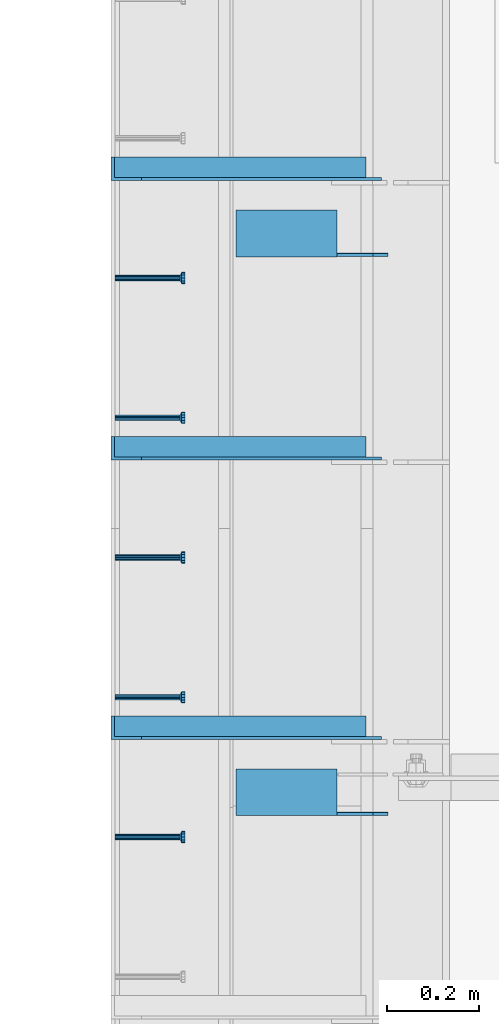
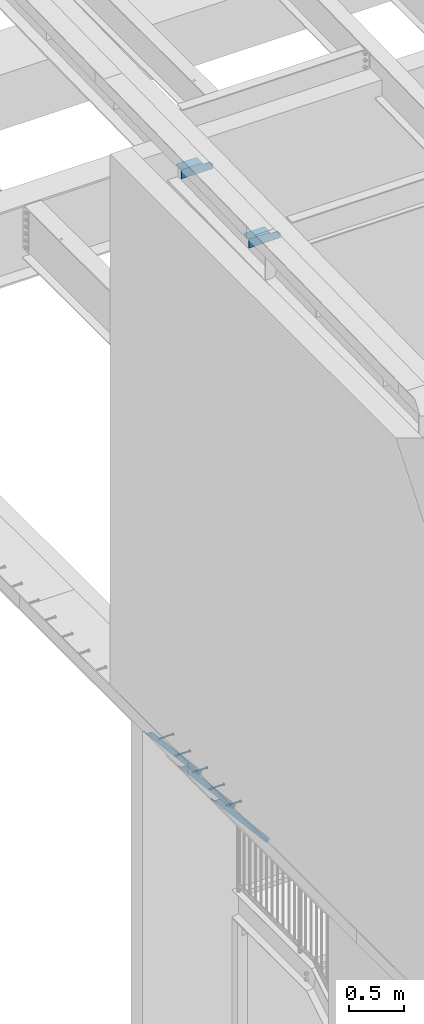
# One storey, part 1270 of 1763: 7 beams, 3 members, 7 elements without a shape of their own.
"""IFC2X3 building model written with IfcOpenShell, lengths in millimetres."""

import ifcopenshell
import ifcopenshell.guid

model = None  # the IFC model being written
_history = None  # IfcOwnerHistory: only IFC2X3 demands one
_inside = {}  # id of a spatial element -> (the spatial element, [elements in it])
_under = {}  # id of a project, library or spatial element -> (it, [spatial elements below it])
_declared = {}  # id of a project -> (the project, [libraries it declares])
_typed = {}  # id of a type object -> (the type object, [elements of that type])
_made_of = {}  # id of a material, layer set ... -> (it, [elements and type objects made of it])


def new_model(schema):
    """Start an empty IFC model of exactly this schema.

    Asked for "IFC4X3", IfcOpenShell would pick the latest addendum, in which some entities
    have other attributes; the version numbers below select the first issue.
    IFC2X3 requires an IfcOwnerHistory on every rooted entity: one is made here for all.
    """
    global model, _history
    if schema == "IFC4X3":
        model = ifcopenshell.file(schema_version=(4, 3, 0, 0))
    else:
        model = ifcopenshell.file(schema=schema)
    _inside.clear()
    _under.clear()
    _declared.clear()
    _typed.clear()
    _made_of.clear()
    _history = None
    if model.schema == "IFC2X3":
        org = make("IfcOrganization", Name="unknown")
        user = make(
            "IfcPersonAndOrganization",
            ThePerson=make("IfcPerson", FamilyName="unknown"),
            TheOrganization=org,
        )
        app = make(
            "IfcApplication",
            ApplicationDeveloper=org,
            Version="unknown",
            ApplicationFullName="unknown",
            ApplicationIdentifier="unknown",
        )
        _history = make(
            "IfcOwnerHistory",
            OwningUser=user,
            OwningApplication=app,
            ChangeAction="ADDED",
            CreationDate=0,
        )
    return model


def make(cls, **values):
    """One entity of the class cls with the attributes given. An attribute that is None is left unset."""
    return model.create_entity(
        cls, **{name: value for name, value in values.items() if value is not None}
    )


def rooted(cls, **values):
    """An entity with a GlobalId (a new one), such as an element, a storey or a relation."""
    return make(cls, GlobalId=ifcopenshell.guid.new(), OwnerHistory=_history, **values)


def si_unit(unit_type, name, prefix=None):
    """IfcSIUnit, for example si_unit("LENGTHUNIT", "METRE", prefix="MILLI")."""
    return make("IfcSIUnit", UnitType=unit_type, Prefix=prefix, Name=name)


def assignment(units):
    """IfcUnitAssignment: the units of a project."""
    return None if units is None else make("IfcUnitAssignment", Units=units)


def point(xyz):
    """IfcCartesianPoint."""
    return None if xyz is None else make("IfcCartesianPoint", Coordinates=xyz)


def direction(xyz):
    """IfcDirection."""
    return None if xyz is None else make("IfcDirection", DirectionRatios=xyz)


def frame(location, z_axis=None, x_axis=None):
    """IfcAxis2Placement3D, a coordinate frame: its origin and axes. An axis left out is left unset."""
    return make(
        "IfcAxis2Placement3D",
        Location=point(location),
        Axis=direction(z_axis),
        RefDirection=direction(x_axis),
    )


def origin_with_axes():
    """The frame at (0, 0, 0) with the z axis (0, 0, 1) and the x axis (1, 0, 0) written out."""
    return frame((0.0, 0.0, 0.0), z_axis=(0.0, 0.0, 1.0), x_axis=(1.0, 0.0, 0.0))


def place(relative_to, where):
    """IfcLocalPlacement: puts the frame where relative to a parent placement (None: the world)."""
    return make(
        "IfcLocalPlacement", PlacementRelTo=relative_to, RelativePlacement=where
    )


def context(
    kind, dimensions, precision=None, world=None, true_north=None, identifier=None
):
    """IfcGeometricRepresentationContext, for example the 3D "Model" context."""
    return make(
        "IfcGeometricRepresentationContext",
        ContextIdentifier=identifier,
        ContextType=kind,
        CoordinateSpaceDimension=dimensions,
        Precision=precision,
        WorldCoordinateSystem=world,
        TrueNorth=true_north,
    )


def subcontext(parent, identifier, kind, view, scale=None):
    """IfcGeometricRepresentationSubContext, for example "Body" below "Model"."""
    return make(
        "IfcGeometricRepresentationSubContext",
        ContextIdentifier=identifier,
        ContextType=kind,
        ParentContext=parent,
        TargetScale=scale,
        TargetView=view,
    )


def project(units=None, contexts=None):
    """IfcProject with its units and contexts."""
    return rooted(
        "IfcProject",
        Name="project",
        RepresentationContexts=contexts,
        UnitsInContext=assignment(units),
    )


def spatial(cls, under=None, at=None, **own):
    """A site, building, storey or space (cls), placed at a placement, below another one or the project."""
    s = rooted(cls, ObjectPlacement=at, **own)
    if under is not None:
        _under.setdefault(under.id(), (under, []))[1].append(s)
    return s


def faces_of(points, faces, orient=None, outer=None):
    """IfcFace entities. A face is a list of loops; a loop is a list of indices into points, from 0.

    orient and outer hold one flag for each loop. By default every Orientation is true, the
    first loop of a face is its IfcFaceOuterBound and the others are IfcFaceBound.
    """
    made = []
    for i, loops in enumerate(faces):
        bounds = []
        for j, loop in enumerate(loops):
            is_outer = j == 0 if outer is None else outer[i][j]
            bounds.append(
                make(
                    "IfcFaceOuterBound" if is_outer else "IfcFaceBound",
                    Bound=make("IfcPolyLoop", Polygon=[points[k] for k in loop]),
                    Orientation=True if orient is None else orient[i][j],
                )
            )
        made.append(make("IfcFace", Bounds=bounds))
    return made


def faceted_brep(points, faces, orient=None, outer=None, voids=None):
    """IfcFacetedBrep: a solid bounded by flat faces; with voids (closed shells), ...WithVoids."""
    shared = [point(p) for p in points]
    hull = make("IfcClosedShell", CfsFaces=faces_of(shared, faces, orient, outer))
    if voids is None:
        return make("IfcFacetedBrep", Outer=hull)
    return make(
        "IfcFacetedBrepWithVoids",
        Outer=hull,
        Voids=[
            make(cls, CfsFaces=faces_of(shared, fs, o, b)) for cls, fs, o, b in voids
        ],
    )


def shape(context_of_items, identifier, shape_type, items):
    """IfcShapeRepresentation: the items that make up one representation, for example the "Body"."""
    return make(
        "IfcShapeRepresentation",
        ContextOfItems=context_of_items,
        RepresentationIdentifier=identifier,
        RepresentationType=shape_type,
        Items=items,
    )


def material(Name=None, Category=None):
    """IfcMaterial."""
    return make("IfcMaterial", Name=Name, Category=Category)


def made_of(thing, what):
    """Note that an element or type object is made of a material, layer set ...; save() writes the relation."""
    if what is not None:
        _made_of.setdefault(what.id(), (what, []))[1].append(thing)
    return thing


def type_object(cls, material=None, **own):
    """A type object (cls), such as IfcWallType, which elements share."""
    return made_of(rooted(cls, **own), material)


def element(
    cls,
    number,
    at=None,
    inside=None,
    cuts=None,
    type_object=None,
    material=None,
    context=None,
    identifier="Body",
    shape_type=None,
    held_by="IfcProductDefinitionShape",
    body=None,
    shapes=None,
    **own,
):
    """One element of the class cls, such as IfcWall. Its Tag is "e" and its number.

    at: its placement. inside: the storey or other place that contains it. cuts: it is an
    opening in that element (IfcRelVoidsElement). A single representation is given by context,
    identifier, shape_type and body (its items); several are given by shapes. held_by: the class
    of the entity that holds the representations. save() writes the other relations.
    """
    e = rooted(cls, Tag="e%d" % number, ObjectPlacement=at, **own)
    if body is not None:
        shapes = [shape(context, identifier, shape_type, body)]
    if shapes is not None:
        e.Representation = make(held_by, Representations=shapes)
    if inside is not None:
        _inside.setdefault(inside.id(), (inside, []))[1].append(e)
    if cuts is not None:
        rooted(
            "IfcRelVoidsElement", RelatingBuildingElement=cuts, RelatedOpeningElement=e
        )
    if type_object is not None:
        _typed.setdefault(type_object.id(), (type_object, []))[1].append(e)
    return made_of(e, material)


def aggregate(whole, parts):
    """IfcRelAggregates: a whole, such as a stair, and the parts it consists of."""
    return rooted("IfcRelAggregates", RelatingObject=whole, RelatedObjects=parts)


def save(model, path):
    """Write the relations noted so far, then the file.

    IfcRelAggregates (storeys below a building ...), IfcRelContainedInSpatialStructure (elements
    in a storey), IfcRelDefinesByType, IfcRelAssociatesMaterial and IfcRelDeclares: one each for
    every whole, place, type object, material and project.
    """
    for whole, parts in _under.values():
        aggregate(whole, parts)
    for where, things in _inside.values():
        rooted(
            "IfcRelContainedInSpatialStructure",
            RelatedElements=things,
            RelatingStructure=where,
        )
    for kind, things in _typed.values():
        rooted("IfcRelDefinesByType", RelatedObjects=things, RelatingType=kind)
    for what, things in _made_of.values():
        rooted("IfcRelAssociatesMaterial", RelatedObjects=things, RelatingMaterial=what)
    for by, libraries in _declared.values():
        rooted("IfcRelDeclares", RelatingContext=by, RelatedDefinitions=libraries)
    model.write(path)


model = new_model("IFC2X3")

# Units and contexts
model_context = context("Model", 3, precision=1e-05, world=origin_with_axes())
body_context = subcontext(model_context, "Body", "Model", "MODEL_VIEW")
ifc_project = project(units=[si_unit("LENGTHUNIT", "METRE", prefix="MILLI"), si_unit("AREAUNIT", "SQUARE_METRE"), si_unit("VOLUMEUNIT", "CUBIC_METRE"), si_unit("MASSUNIT", "GRAM", prefix="KILO"), si_unit("TIMEUNIT", "SECOND"), si_unit("PLANEANGLEUNIT", "RADIAN"), si_unit("SOLIDANGLEUNIT", "STERADIAN"), si_unit("THERMODYNAMICTEMPERATUREUNIT", "DEGREE_CELSIUS"), si_unit("LUMINOUSINTENSITYUNIT", "LUMEN")], contexts=[model_context])

# Site, building, storey
site_placement = place(None, origin_with_axes())
site = spatial("IfcSite", under=ifc_project, at=site_placement, CompositionType="ELEMENT")
building_placement = place(site_placement, origin_with_axes())
building = spatial("IfcBuilding", under=site, at=building_placement, Name="Undefined", CompositionType="ELEMENT")
storey_placement = place(building_placement, origin_with_axes())
storey = spatial("IfcBuildingStorey", under=building, at=storey_placement, Name="Undefined", CompositionType="ELEMENT", Elevation=0.0)

# Assembly, beam
assembly_1_placement = place(storey_placement, origin_with_axes())
assembly_1 = element("IfcElementAssembly", 1, at=assembly_1_placement, inside=storey, Name="HEADED STUD ANCHOR", AssemblyPlace="NOTDEFINED", PredefinedType="RIGID_FRAME")
ifc_material_1 = material(Name="STEEL/A108")
beam_type_1 = type_object("IfcBeamType", PredefinedType="NOTDEFINED")
beam_1_placement = place(assembly_1_placement, frame((-87975.5122736983, 35448.8750061035, 5268.91250001202), z_axis=(0.0, 0.0, -1.0), x_axis=(1.0, 0.0, 0.0)))
beam_1 = element("IfcBeam", 2, at=beam_1_placement, type_object=beam_type_1, material=ifc_material_1, Name="HEADED STUD ANCHOR", context=body_context, shape_type="Brep", body=[
    faceted_brep([(0.0, -3.1800000667572, 5.5), (0.0, -5.5, 3.1800000667572), (141.732000000002, -5.5, 3.1800000667572), (141.732000000002, -3.1800000667572, 5.5), (0.0, -6.34999999999491, 1.45519152283669e-11), (141.732000000002, -6.34999990463257, 0.0), (0.0, -5.5, -3.1800000667572), (141.732000000002, -5.5, -3.1800000667572), (0.0, -3.1800000667572, -5.5), (141.732000000002, -3.1800000667572, -5.5), (0.0, 0.0, -6.34999990463257), (141.732000000002, 0.0, -6.34999990463257), (0.0, 3.1800000667572, -5.5), (141.732000000002, 3.1800000667572, -5.5), (0.0, 5.5, -3.1800000667572), (141.732000000002, 5.5, -3.1800000667572), (0.0, 6.34999999999491, -2.91038304567337e-11), (141.732000000002, 6.34999990463257, 0.0), (0.0, 5.5, 3.1800000667572), (141.732000000002, 5.5, 3.1800000667572), (0.0, 3.1800000667572, 5.5), (141.732000000002, 3.1800000667572, 5.5), (0.0, 0.0, 6.34999990463257), (141.732000000002, 0.0, 6.34999990463257), (144.780000000001, -10.9899997711182, 6.34999990463257), (144.780000000001, -6.34000015258789, 10.9899997711182), (144.780000000001, -12.6999998092651, 0.0), (144.780000000001, -10.9899997711182, -6.34999990463257), (144.780000000001, -6.34000015258789, -10.9899997711182), (144.780000000001, 0.0, -12.6899995803833), (144.780000000001, 6.34000015258789, -10.9899997711182), (144.780000000001, 10.9899997711182, -6.34999990463257), (144.780000000001, 12.6999998092651, 0.0), (144.780000000001, 10.9899997711182, 6.34999990463257), (144.780000000001, 6.34000015258789, 10.9899997711182), (144.780000000001, 0.0, 12.6899995803833), (152.400000000001, -10.9899997711182, 6.34999990463257), (152.400000000001, -6.34000015258789, 10.9899997711182), (152.400000000001, -12.6999998092651, 0.0), (152.400000000001, -10.9899997711182, -6.34999990463257), (152.400000000001, -6.34000015258789, -10.9899997711182), (152.400000000001, 0.0, -12.6899995803833), (152.400000000001, 6.34000015258789, -10.9899997711182), (152.400000000001, 10.9899997711182, -6.34999990463257), (152.400000000001, 12.6999998092651, 0.0), (152.400000000001, 10.9899997711182, 6.34999990463257), (152.400000000001, 6.34000015258789, 10.9899997711182), (152.400000000001, 0.0, 12.6899995803833)], [[[0, 1, 2, 3]], [[1, 4, 5, 2]], [[4, 6, 7, 5]], [[6, 8, 9, 7]], [[8, 10, 11, 9]], [[10, 12, 13, 11]], [[12, 14, 15, 13]], [[14, 16, 17, 15]], [[16, 18, 19, 17]], [[18, 20, 21, 19]], [[20, 22, 23, 21]], [[22, 0, 3, 23]], [[22, 20, 18, 16, 14, 12, 10, 8, 6, 4, 1, 0]], [[3, 2, 24, 25]], [[2, 5, 26, 24]], [[5, 7, 27, 26]], [[7, 9, 28, 27]], [[9, 11, 29, 28]], [[11, 13, 30, 29]], [[13, 15, 31, 30]], [[15, 17, 32, 31]], [[17, 19, 33, 32]], [[19, 21, 34, 33]], [[21, 23, 35, 34]], [[23, 3, 25, 35]], [[25, 24, 36, 37]], [[24, 26, 38, 36]], [[26, 27, 39, 38]], [[27, 28, 40, 39]], [[28, 29, 41, 40]], [[29, 30, 42, 41]], [[30, 31, 43, 42]], [[31, 32, 44, 43]], [[32, 33, 45, 44]], [[33, 34, 46, 45]], [[34, 35, 47, 46]], [[35, 25, 37, 47]], [[38, 39, 40, 41, 42, 43, 44, 45, 46, 47, 37, 36]]]),
])
aggregate(assembly_1, [beam_1])

assembly_2_placement = place(storey_placement, origin_with_axes())
assembly_2 = element("IfcElementAssembly", 3, at=assembly_2_placement, inside=storey, Name="HEADED STUD ANCHOR", AssemblyPlace="NOTDEFINED", PredefinedType="RIGID_FRAME")
beam_2_placement = place(assembly_2_placement, frame((-87975.5122736983, 35753.6750061035, 5268.91250001202), z_axis=(0.0, 0.0, -1.0), x_axis=(1.0, 0.0, 0.0)))
beam_2 = element("IfcBeam", 4, at=beam_2_placement, type_object=beam_type_1, material=ifc_material_1, Name="HEADED STUD ANCHOR", context=body_context, shape_type="Brep", body=[
    faceted_brep([(0.0, -3.1800000667572, 5.5), (0.0, -5.5, 3.1800000667572), (141.732000000002, -5.5, 3.1800000667572), (141.732000000002, -3.1800000667572, 5.5), (0.0, -6.34999999999491, 1.45519152283669e-11), (141.732000000002, -6.34999990463257, 0.0), (0.0, -5.5, -3.1800000667572), (141.732000000002, -5.5, -3.1800000667572), (0.0, -3.1800000667572, -5.5), (141.732000000002, -3.1800000667572, -5.5), (0.0, 0.0, -6.34999990463257), (141.732000000002, 0.0, -6.34999990463257), (0.0, 3.1800000667572, -5.5), (141.732000000002, 3.1800000667572, -5.5), (0.0, 5.5, -3.1800000667572), (141.732000000002, 5.5, -3.1800000667572), (0.0, 6.34999999999491, -2.91038304567337e-11), (141.732000000002, 6.34999990463257, 0.0), (0.0, 5.5, 3.1800000667572), (141.732000000002, 5.5, 3.1800000667572), (0.0, 3.1800000667572, 5.5), (141.732000000002, 3.1800000667572, 5.5), (0.0, 0.0, 6.34999990463257), (141.732000000002, 0.0, 6.34999990463257), (144.780000000001, -10.9899997711182, 6.34999990463257), (144.780000000001, -6.34000015258789, 10.9899997711182), (144.780000000001, -12.6999998092651, 0.0), (144.780000000001, -10.9899997711182, -6.34999990463257), (144.780000000001, -6.34000015258789, -10.9899997711182), (144.780000000001, 0.0, -12.6899995803833), (144.780000000001, 6.34000015258789, -10.9899997711182), (144.780000000001, 10.9899997711182, -6.34999990463257), (144.780000000001, 12.6999998092651, 0.0), (144.780000000001, 10.9899997711182, 6.34999990463257), (144.780000000001, 6.34000015258789, 10.9899997711182), (144.780000000001, 0.0, 12.6899995803833), (152.400000000001, -10.9899997711182, 6.34999990463257), (152.400000000001, -6.34000015258789, 10.9899997711182), (152.400000000001, -12.6999998092651, 0.0), (152.400000000001, -10.9899997711182, -6.34999990463257), (152.400000000001, -6.34000015258789, -10.9899997711182), (152.400000000001, 0.0, -12.6899995803833), (152.400000000001, 6.34000015258789, -10.9899997711182), (152.400000000001, 10.9899997711182, -6.34999990463257), (152.400000000001, 12.6999998092651, 0.0), (152.400000000001, 10.9899997711182, 6.34999990463257), (152.400000000001, 6.34000015258789, 10.9899997711182), (152.400000000001, 0.0, 12.6899995803833)], [[[0, 1, 2, 3]], [[1, 4, 5, 2]], [[4, 6, 7, 5]], [[6, 8, 9, 7]], [[8, 10, 11, 9]], [[10, 12, 13, 11]], [[12, 14, 15, 13]], [[14, 16, 17, 15]], [[16, 18, 19, 17]], [[18, 20, 21, 19]], [[20, 22, 23, 21]], [[22, 0, 3, 23]], [[22, 20, 18, 16, 14, 12, 10, 8, 6, 4, 1, 0]], [[3, 2, 24, 25]], [[2, 5, 26, 24]], [[5, 7, 27, 26]], [[7, 9, 28, 27]], [[9, 11, 29, 28]], [[11, 13, 30, 29]], [[13, 15, 31, 30]], [[15, 17, 32, 31]], [[17, 19, 33, 32]], [[19, 21, 34, 33]], [[21, 23, 35, 34]], [[23, 3, 25, 35]], [[25, 24, 36, 37]], [[24, 26, 38, 36]], [[26, 27, 39, 38]], [[27, 28, 40, 39]], [[28, 29, 41, 40]], [[29, 30, 42, 41]], [[30, 31, 43, 42]], [[31, 32, 44, 43]], [[32, 33, 45, 44]], [[33, 34, 46, 45]], [[34, 35, 47, 46]], [[35, 25, 37, 47]], [[38, 39, 40, 41, 42, 43, 44, 45, 46, 47, 37, 36]]]),
])
aggregate(assembly_2, [beam_2])

assembly_3_placement = place(storey_placement, origin_with_axes())
assembly_3 = element("IfcElementAssembly", 5, at=assembly_3_placement, inside=storey, Name="HEADED STUD ANCHOR", AssemblyPlace="NOTDEFINED", PredefinedType="RIGID_FRAME")
beam_3_placement = place(assembly_3_placement, frame((-87975.5122736983, 36058.4750061035, 5268.91250001202), z_axis=(0.0, 0.0, -1.0), x_axis=(1.0, 0.0, 0.0)))
beam_3 = element("IfcBeam", 6, at=beam_3_placement, type_object=beam_type_1, material=ifc_material_1, Name="HEADED STUD ANCHOR", context=body_context, shape_type="Brep", body=[
    faceted_brep([(0.0, -3.1800000667572, 5.5), (0.0, -5.5, 3.1800000667572), (141.732000000002, -5.5, 3.1800000667572), (141.732000000002, -3.1800000667572, 5.5), (0.0, -6.34999999999491, 1.45519152283669e-11), (141.732000000002, -6.34999990463257, 0.0), (0.0, -5.5, -3.1800000667572), (141.732000000002, -5.5, -3.1800000667572), (0.0, -3.1800000667572, -5.5), (141.732000000002, -3.1800000667572, -5.5), (0.0, 0.0, -6.34999990463257), (141.732000000002, 0.0, -6.34999990463257), (0.0, 3.1800000667572, -5.5), (141.732000000002, 3.1800000667572, -5.5), (0.0, 5.5, -3.1800000667572), (141.732000000002, 5.5, -3.1800000667572), (0.0, 6.34999999999491, -2.91038304567337e-11), (141.732000000002, 6.34999990463257, 0.0), (0.0, 5.5, 3.1800000667572), (141.732000000002, 5.5, 3.1800000667572), (0.0, 3.1800000667572, 5.5), (141.732000000002, 3.1800000667572, 5.5), (0.0, 0.0, 6.34999990463257), (141.732000000002, 0.0, 6.34999990463257), (144.780000000001, -10.9899997711182, 6.34999990463257), (144.780000000001, -6.34000015258789, 10.9899997711182), (144.780000000001, -12.6999998092651, 0.0), (144.780000000001, -10.9899997711182, -6.34999990463257), (144.780000000001, -6.34000015258789, -10.9899997711182), (144.780000000001, 0.0, -12.6899995803833), (144.780000000001, 6.34000015258789, -10.9899997711182), (144.780000000001, 10.9899997711182, -6.34999990463257), (144.780000000001, 12.6999998092651, 0.0), (144.780000000001, 10.9899997711182, 6.34999990463257), (144.780000000001, 6.34000015258789, 10.9899997711182), (144.780000000001, 0.0, 12.6899995803833), (152.400000000001, -10.9899997711182, 6.34999990463257), (152.400000000001, -6.34000015258789, 10.9899997711182), (152.400000000001, -12.6999998092651, 0.0), (152.400000000001, -10.9899997711182, -6.34999990463257), (152.400000000001, -6.34000015258789, -10.9899997711182), (152.400000000001, 0.0, -12.6899995803833), (152.400000000001, 6.34000015258789, -10.9899997711182), (152.400000000001, 10.9899997711182, -6.34999990463257), (152.400000000001, 12.6999998092651, 0.0), (152.400000000001, 10.9899997711182, 6.34999990463257), (152.400000000001, 6.34000015258789, 10.9899997711182), (152.400000000001, 0.0, 12.6899995803833)], [[[0, 1, 2, 3]], [[1, 4, 5, 2]], [[4, 6, 7, 5]], [[6, 8, 9, 7]], [[8, 10, 11, 9]], [[10, 12, 13, 11]], [[12, 14, 15, 13]], [[14, 16, 17, 15]], [[16, 18, 19, 17]], [[18, 20, 21, 19]], [[20, 22, 23, 21]], [[22, 0, 3, 23]], [[22, 20, 18, 16, 14, 12, 10, 8, 6, 4, 1, 0]], [[3, 2, 24, 25]], [[2, 5, 26, 24]], [[5, 7, 27, 26]], [[7, 9, 28, 27]], [[9, 11, 29, 28]], [[11, 13, 30, 29]], [[13, 15, 31, 30]], [[15, 17, 32, 31]], [[17, 19, 33, 32]], [[19, 21, 34, 33]], [[21, 23, 35, 34]], [[23, 3, 25, 35]], [[25, 24, 36, 37]], [[24, 26, 38, 36]], [[26, 27, 39, 38]], [[27, 28, 40, 39]], [[28, 29, 41, 40]], [[29, 30, 42, 41]], [[30, 31, 43, 42]], [[31, 32, 44, 43]], [[32, 33, 45, 44]], [[33, 34, 46, 45]], [[34, 35, 47, 46]], [[35, 25, 37, 47]], [[38, 39, 40, 41, 42, 43, 44, 45, 46, 47, 37, 36]]]),
])
aggregate(assembly_3, [beam_3])

assembly_4_placement = place(storey_placement, origin_with_axes())
assembly_4 = element("IfcElementAssembly", 7, at=assembly_4_placement, inside=storey, Name="HEADED STUD ANCHOR", AssemblyPlace="NOTDEFINED", PredefinedType="RIGID_FRAME")
beam_4_placement = place(assembly_4_placement, frame((-87975.5122736983, 36363.2750061035, 5268.91250001202), z_axis=(0.0, 0.0, -1.0), x_axis=(1.0, 0.0, 0.0)))
beam_4 = element("IfcBeam", 8, at=beam_4_placement, type_object=beam_type_1, material=ifc_material_1, Name="HEADED STUD ANCHOR", context=body_context, shape_type="Brep", body=[
    faceted_brep([(0.0, -3.1800000667572, 5.5), (0.0, -5.5, 3.1800000667572), (141.732000000002, -5.5, 3.1800000667572), (141.732000000002, -3.1800000667572, 5.5), (0.0, -6.34999999999491, 1.45519152283669e-11), (141.732000000002, -6.34999990463257, 0.0), (0.0, -5.5, -3.1800000667572), (141.732000000002, -5.5, -3.1800000667572), (0.0, -3.1800000667572, -5.5), (141.732000000002, -3.1800000667572, -5.5), (0.0, 0.0, -6.34999990463257), (141.732000000002, 0.0, -6.34999990463257), (0.0, 3.1800000667572, -5.5), (141.732000000002, 3.1800000667572, -5.5), (0.0, 5.5, -3.1800000667572), (141.732000000002, 5.5, -3.1800000667572), (0.0, 6.34999999999491, -2.91038304567337e-11), (141.732000000002, 6.34999990463257, 0.0), (0.0, 5.5, 3.1800000667572), (141.732000000002, 5.5, 3.1800000667572), (0.0, 3.1800000667572, 5.5), (141.732000000002, 3.1800000667572, 5.5), (0.0, 0.0, 6.34999990463257), (141.732000000002, 0.0, 6.34999990463257), (144.780000000001, -10.9899997711182, 6.34999990463257), (144.780000000001, -6.34000015258789, 10.9899997711182), (144.780000000001, -12.6999998092651, 0.0), (144.780000000001, -10.9899997711182, -6.34999990463257), (144.780000000001, -6.34000015258789, -10.9899997711182), (144.780000000001, 0.0, -12.6899995803833), (144.780000000001, 6.34000015258789, -10.9899997711182), (144.780000000001, 10.9899997711182, -6.34999990463257), (144.780000000001, 12.6999998092651, 0.0), (144.780000000001, 10.9899997711182, 6.34999990463257), (144.780000000001, 6.34000015258789, 10.9899997711182), (144.780000000001, 0.0, 12.6899995803833), (152.400000000001, -10.9899997711182, 6.34999990463257), (152.400000000001, -6.34000015258789, 10.9899997711182), (152.400000000001, -12.6999998092651, 0.0), (152.400000000001, -10.9899997711182, -6.34999990463257), (152.400000000001, -6.34000015258789, -10.9899997711182), (152.400000000001, 0.0, -12.6899995803833), (152.400000000001, 6.34000015258789, -10.9899997711182), (152.400000000001, 10.9899997711182, -6.34999990463257), (152.400000000001, 12.6999998092651, 0.0), (152.400000000001, 10.9899997711182, 6.34999990463257), (152.400000000001, 6.34000015258789, 10.9899997711182), (152.400000000001, 0.0, 12.6899995803833)], [[[0, 1, 2, 3]], [[1, 4, 5, 2]], [[4, 6, 7, 5]], [[6, 8, 9, 7]], [[8, 10, 11, 9]], [[10, 12, 13, 11]], [[12, 14, 15, 13]], [[14, 16, 17, 15]], [[16, 18, 19, 17]], [[18, 20, 21, 19]], [[20, 22, 23, 21]], [[22, 0, 3, 23]], [[22, 20, 18, 16, 14, 12, 10, 8, 6, 4, 1, 0]], [[3, 2, 24, 25]], [[2, 5, 26, 24]], [[5, 7, 27, 26]], [[7, 9, 28, 27]], [[9, 11, 29, 28]], [[11, 13, 30, 29]], [[13, 15, 31, 30]], [[15, 17, 32, 31]], [[17, 19, 33, 32]], [[19, 21, 34, 33]], [[21, 23, 35, 34]], [[23, 3, 25, 35]], [[25, 24, 36, 37]], [[24, 26, 38, 36]], [[26, 27, 39, 38]], [[27, 28, 40, 39]], [[28, 29, 41, 40]], [[29, 30, 42, 41]], [[30, 31, 43, 42]], [[31, 32, 44, 43]], [[32, 33, 45, 44]], [[33, 34, 46, 45]], [[34, 35, 47, 46]], [[35, 25, 37, 47]], [[38, 39, 40, 41, 42, 43, 44, 45, 46, 47, 37, 36]]]),
])
aggregate(assembly_4, [beam_4])

assembly_5_placement = place(storey_placement, origin_with_axes())
assembly_5 = element("IfcElementAssembly", 9, at=assembly_5_placement, inside=storey, Name="HEADED STUD ANCHOR", AssemblyPlace="NOTDEFINED", PredefinedType="RIGID_FRAME")
beam_5_placement = place(assembly_5_placement, frame((-87975.5122736983, 36668.0750061035, 5268.91250001202), z_axis=(0.0, 0.0, -1.0), x_axis=(1.0, 0.0, 0.0)))
beam_5 = element("IfcBeam", 10, at=beam_5_placement, type_object=beam_type_1, material=ifc_material_1, Name="HEADED STUD ANCHOR", context=body_context, shape_type="Brep", body=[
    faceted_brep([(0.0, -3.1800000667572, 5.5), (0.0, -5.5, 3.1800000667572), (141.732000000002, -5.5, 3.1800000667572), (141.732000000002, -3.1800000667572, 5.5), (0.0, -6.34999999999491, 1.45519152283669e-11), (141.732000000002, -6.34999990463257, 0.0), (0.0, -5.5, -3.1800000667572), (141.732000000002, -5.5, -3.1800000667572), (0.0, -3.1800000667572, -5.5), (141.732000000002, -3.1800000667572, -5.5), (0.0, 0.0, -6.34999990463257), (141.732000000002, 0.0, -6.34999990463257), (0.0, 3.1800000667572, -5.5), (141.732000000002, 3.1800000667572, -5.5), (0.0, 5.5, -3.1800000667572), (141.732000000002, 5.5, -3.1800000667572), (0.0, 6.34999999999491, -2.91038304567337e-11), (141.732000000002, 6.34999990463257, 0.0), (0.0, 5.5, 3.1800000667572), (141.732000000002, 5.5, 3.1800000667572), (0.0, 3.1800000667572, 5.5), (141.732000000002, 3.1800000667572, 5.5), (0.0, 0.0, 6.34999990463257), (141.732000000002, 0.0, 6.34999990463257), (144.780000000001, -10.9899997711182, 6.34999990463257), (144.780000000001, -6.34000015258789, 10.9899997711182), (144.780000000001, -12.6999998092651, 0.0), (144.780000000001, -10.9899997711182, -6.34999990463257), (144.780000000001, -6.34000015258789, -10.9899997711182), (144.780000000001, 0.0, -12.6899995803833), (144.780000000001, 6.34000015258789, -10.9899997711182), (144.780000000001, 10.9899997711182, -6.34999990463257), (144.780000000001, 12.6999998092651, 0.0), (144.780000000001, 10.9899997711182, 6.34999990463257), (144.780000000001, 6.34000015258789, 10.9899997711182), (144.780000000001, 0.0, 12.6899995803833), (152.400000000001, -10.9899997711182, 6.34999990463257), (152.400000000001, -6.34000015258789, 10.9899997711182), (152.400000000001, -12.6999998092651, 0.0), (152.400000000001, -10.9899997711182, -6.34999990463257), (152.400000000001, -6.34000015258789, -10.9899997711182), (152.400000000001, 0.0, -12.6899995803833), (152.400000000001, 6.34000015258789, -10.9899997711182), (152.400000000001, 10.9899997711182, -6.34999990463257), (152.400000000001, 12.6999998092651, 0.0), (152.400000000001, 10.9899997711182, 6.34999990463257), (152.400000000001, 6.34000015258789, 10.9899997711182), (152.400000000001, 0.0, 12.6899995803833)], [[[0, 1, 2, 3]], [[1, 4, 5, 2]], [[4, 6, 7, 5]], [[6, 8, 9, 7]], [[8, 10, 11, 9]], [[10, 12, 13, 11]], [[12, 14, 15, 13]], [[14, 16, 17, 15]], [[16, 18, 19, 17]], [[18, 20, 21, 19]], [[20, 22, 23, 21]], [[22, 0, 3, 23]], [[22, 20, 18, 16, 14, 12, 10, 8, 6, 4, 1, 0]], [[3, 2, 24, 25]], [[2, 5, 26, 24]], [[5, 7, 27, 26]], [[7, 9, 28, 27]], [[9, 11, 29, 28]], [[11, 13, 30, 29]], [[13, 15, 31, 30]], [[15, 17, 32, 31]], [[17, 19, 33, 32]], [[19, 21, 34, 33]], [[21, 23, 35, 34]], [[23, 3, 25, 35]], [[25, 24, 36, 37]], [[24, 26, 38, 36]], [[26, 27, 39, 38]], [[27, 28, 40, 39]], [[28, 29, 41, 40]], [[29, 30, 42, 41]], [[30, 31, 43, 42]], [[31, 32, 44, 43]], [[32, 33, 45, 44]], [[33, 34, 46, 45]], [[34, 35, 47, 46]], [[35, 25, 37, 47]], [[38, 39, 40, 41, 42, 43, 44, 45, 46, 47, 37, 36]]]),
])
aggregate(assembly_5, [beam_5])

# Assembly, members
assembly_6_placement = place(storey_placement, origin_with_axes())
assembly_6 = element("IfcElementAssembly", 11, at=assembly_6_placement, inside=storey, Name="BEAM", AssemblyPlace="NOTDEFINED", PredefinedType="RIGID_FRAME")
ifc_material_2 = material(Name="STEEL/A36")
member_type = type_object("IfcMemberType", Name="L2X2X1/4", PredefinedType="NOTDEFINED")
member_1_placement = place(assembly_6_placement, frame((-87414.1929584935, 36296.6, 4557.35349338836), z_axis=(0.764183480307171, 0.0, 0.644998921259268), x_axis=(-0.644998921259266, 0.0, 0.764183480307173)))
member_1 = element("IfcMember", 12, at=member_1_placement, type_object=member_type, material=ifc_material_2, Name="ANGLE", ObjectType="L2X2X1/4", context=body_context, shape_type="Brep", body=[
    faceted_brep([(-1.45519152283669e-11, 25.4000000000015, -25.3999999999869), (1.45519152283669e-11, 25.4000000000015, 25.3999999999796), (812.060911532491, 25.4000000000015, 25.400000001966), (854.937976763787, 25.4000000000015, -25.3999999979424), (1.45519152283669e-11, 19.0499999999993, 25.3999999999796), (812.060911532491, 19.0500000000029, 25.400000001966), (-7.27595761418343e-12, 19.0499999999993, -19.0499999999956), (849.578343609872, 19.0500000000029, -19.0499999979511), (-7.27595761418343e-12, -25.4000000000015, -19.0499999999956), (849.578343609872, -25.4000000000015, -19.0499999979511), (-1.45519152283669e-11, -25.4000000000015, -25.3999999999869), (854.937976763787, -25.4000000000015, -25.3999999979424)], [[[0, 1, 2, 3]], [[1, 4, 5, 2]], [[4, 6, 7, 5]], [[6, 8, 9, 7]], [[8, 10, 11, 9]], [[10, 0, 3, 11]], [[5, 7, 9, 11, 3, 2]], [[10, 8, 6, 4, 1, 0]]]),
])
member_2_placement = place(assembly_6_placement, frame((-87414.1929584935, 35687.0, 4557.35349338836), z_axis=(0.764183480307171, 0.0, 0.644998921259268), x_axis=(-0.644998921259266, 0.0, 0.764183480307173)))
member_2 = element("IfcMember", 13, at=member_2_placement, type_object=member_type, material=ifc_material_2, Name="ANGLE", ObjectType="L2X2X1/4", context=body_context, shape_type="Brep", body=[
    faceted_brep([(-1.45519152283669e-11, 25.4000000000015, -25.3999999999869), (1.45519152283669e-11, 25.4000000000015, 25.3999999999796), (812.060911532491, 25.4000000000015, 25.400000001966), (854.937976763787, 25.4000000000015, -25.3999999979424), (1.45519152283669e-11, 19.0499999999993, 25.3999999999796), (812.060911532491, 19.0500000000029, 25.400000001966), (-7.27595761418343e-12, 19.0499999999993, -19.0499999999956), (849.578343609872, 19.0500000000029, -19.0499999979511), (-7.27595761418343e-12, -25.4000000000015, -19.0499999999956), (849.578343609872, -25.4000000000015, -19.0499999979511), (-1.45519152283669e-11, -25.4000000000015, -25.3999999999869), (854.937976763787, -25.4000000000015, -25.3999999979424)], [[[0, 1, 2, 3]], [[1, 4, 5, 2]], [[4, 6, 7, 5]], [[6, 8, 9, 7]], [[8, 10, 11, 9]], [[10, 0, 3, 11]], [[5, 7, 9, 11, 3, 2]], [[10, 8, 6, 4, 1, 0]]]),
])
member_3_placement = place(assembly_6_placement, frame((-87414.1929584935, 36906.2, 4557.35349338836), z_axis=(0.764183480307171, 0.0, 0.644998921259268), x_axis=(-0.644998921259266, 0.0, 0.764183480307173)))
member_3 = element("IfcMember", 14, at=member_3_placement, type_object=member_type, material=ifc_material_2, Name="ANGLE", ObjectType="L2X2X1/4", context=body_context, shape_type="Brep", body=[
    faceted_brep([(-1.45519152283669e-11, 25.4000000000015, -25.3999999999869), (1.45519152283669e-11, 25.4000000000015, 25.3999999999796), (812.060911532491, 25.4000000000015, 25.400000001966), (854.937976763787, 25.4000000000015, -25.3999999979424), (1.45519152283669e-11, 19.0499999999993, 25.3999999999796), (812.060911532491, 19.0500000000029, 25.400000001966), (-7.27595761418343e-12, 19.0499999999993, -19.0499999999956), (849.578343609872, 19.0500000000029, -19.0499999979511), (-7.27595761418343e-12, -25.4000000000015, -19.0499999999956), (849.578343609872, -25.4000000000015, -19.0499999979511), (-1.45519152283669e-11, -25.4000000000015, -25.3999999999869), (854.937976763787, -25.4000000000015, -25.3999999979424)], [[[0, 1, 2, 3]], [[1, 4, 5, 2]], [[4, 6, 7, 5]], [[6, 8, 9, 7]], [[8, 10, 11, 9]], [[10, 0, 3, 11]], [[5, 7, 9, 11, 3, 2]], [[10, 8, 6, 4, 1, 0]]]),
])
aggregate(assembly_6, [member_1, member_2, member_3])

# Assembly, beams
assembly_7_placement = place(storey_placement, origin_with_axes())
assembly_7 = element("IfcElementAssembly", 15, at=assembly_7_placement, inside=storey, Name="BEAM", AssemblyPlace="NOTDEFINED", PredefinedType="RIGID_FRAME")
beam_type_2 = type_object("IfcBeamType", Name="L4X4X1/4", PredefinedType="NOTDEFINED")
beam_6_placement = place(assembly_7_placement, frame((-87711.9872706466, 36766.1328559311, 11379.0063573758), z_axis=(0.0, 0.0206852279954837, -0.999786037781472), x_axis=(1.0, 0.0, 0.0)))
beam_6 = element("IfcBeam", 16, at=beam_6_placement, type_object=beam_type_2, material=ifc_material_2, Name="BRACE", ObjectType="L4X4X1/4", context=body_context, shape_type="Brep", body=[
    faceted_brep([(220.662761923406, 44.4500000001208, -44.4499999999807), (220.662761962012, -50.800000000163, -44.4499999999553), (220.66276795695, -50.800000000163, -50.7999999999502), (220.662767915564, 50.8000000001339, -50.7999999999774), (220.662751535681, 50.8000000001339, -33.3786578752915), (220.662751538272, 44.4500000001208, -33.3786578752897), (299.243730570859, 44.4500000001135, -33.3375021376705), (299.243730570859, 50.8000000001339, -33.3375021376723), (2.11002770811319e-10, -50.8000000000357, -50.799999999952), (1.96450855582952e-10, -50.8000000000338, -44.4499999999534), (-2.18278728425503e-11, 44.4500000000007, -44.450000000048), (-1.81898940354586e-10, 44.4500000000371, 50.7999999999374), (-1.96450855582952e-10, 50.8000000000393, 50.7999999999374), (-3.63797880709171e-11, 50.8000000000011, -50.8000000000538), (330.993731689443, 44.4500000000007, 50.7999999999993), (330.993731689443, 50.7999999999993, 50.7999999999993), (330.993730570859, 44.4500000001281, -1.58750213774329), (330.993746948254, 50.8000000001412, -1.5875021377451)], [[[0, 1, 2, 3, 4, 5]], [[6, 5, 4, 7]], [[8, 9, 10, 11, 12, 13]], [[12, 11, 14, 15]], [[15, 14, 16, 17]], [[17, 16, 6, 7]], [[3, 13, 12, 15, 17, 7, 4]], [[8, 13, 3, 2]], [[9, 8, 2, 1]], [[10, 9, 1, 0]], [[16, 14, 11, 10, 0, 5, 6]]]),
])
beam_7_placement = place(assembly_7_placement, frame((-87711.9872706466, 35547.1937186681, 11353.7869274038), z_axis=(0.0, 0.0206852279954837, -0.999786037781472), x_axis=(1.0, 0.0, 0.0)))
beam_7 = element("IfcBeam", 17, at=beam_7_placement, type_object=beam_type_2, material=ifc_material_2, Name="BRACE", ObjectType="L4X4X1/4", context=body_context, shape_type="Brep", body=[
    faceted_brep([(220.662761923406, 44.4500000001208, -44.4499999999807), (220.662761962012, -50.800000000163, -44.4499999999553), (220.66276795695, -50.800000000163, -50.7999999999502), (220.662767915564, 50.8000000001339, -50.7999999999774), (220.662751535681, 50.8000000001339, -33.3786578752915), (220.662751538272, 44.4500000001208, -33.3786578752897), (299.243730570859, 44.4500000001135, -33.3375021376705), (299.243730570859, 50.8000000001339, -33.3375021376723), (2.11002770811319e-10, -50.8000000000357, -50.799999999952), (1.96450855582952e-10, -50.8000000000338, -44.4499999999534), (-2.18278728425503e-11, 44.4500000000007, -44.450000000048), (-1.81898940354586e-10, 44.4500000000371, 50.7999999999374), (-1.96450855582952e-10, 50.8000000000393, 50.7999999999374), (-3.63797880709171e-11, 50.8000000000011, -50.8000000000538), (330.993731689443, 44.4500000000007, 50.7999999999993), (330.993731689443, 50.7999999999993, 50.7999999999993), (330.993730570859, 44.4500000001281, -1.58750213774329), (330.993746948254, 50.8000000001412, -1.5875021377451)], [[[0, 1, 2, 3, 4, 5]], [[6, 5, 4, 7]], [[8, 9, 10, 11, 12, 13]], [[12, 11, 14, 15]], [[15, 14, 16, 17]], [[17, 16, 6, 7]], [[3, 13, 12, 15, 17, 7, 4]], [[8, 13, 3, 2]], [[9, 8, 2, 1]], [[10, 9, 1, 0]], [[16, 14, 11, 10, 0, 5, 6]]]),
])
aggregate(assembly_7, [beam_6, beam_7])

save(model, "model.ifc")
